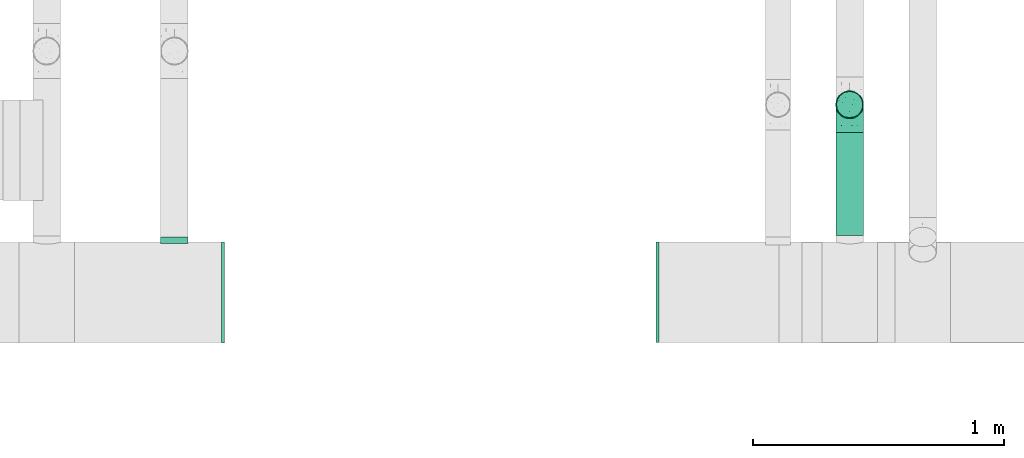
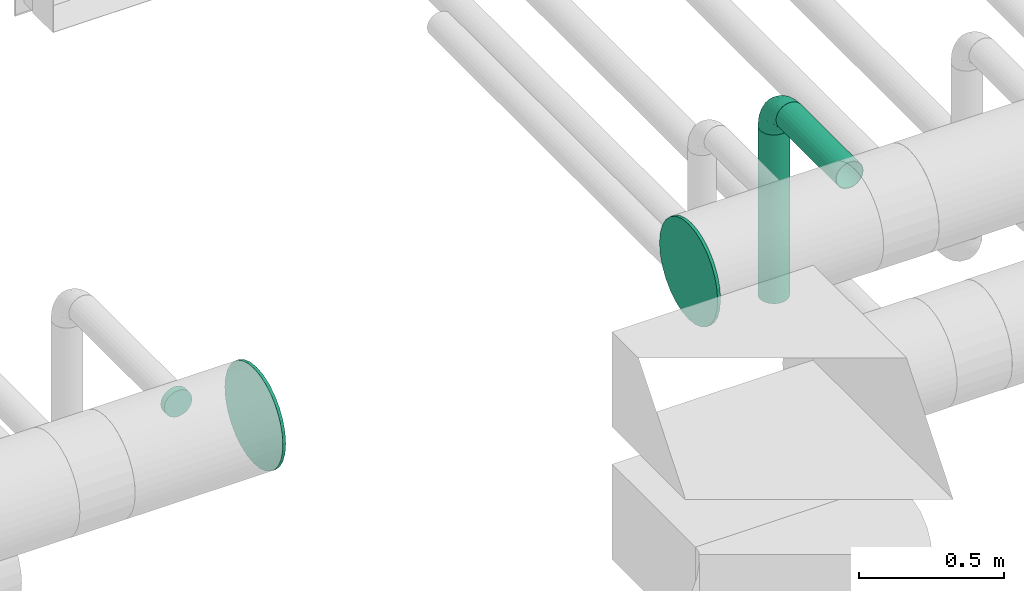
# One storey, part 72 of 91: 4 flow fittings, 2 flow segments.
"""IFC2X3 building model written with IfcOpenShell, lengths in millimetres."""

from ifc_helpers import new_model, entity, si_unit, converted_unit, derived_unit, direction, frame, origin_with_axes, origin_2d_with_axis, place, context, subcontext, project, spatial, hollow_circle, extrude, open_shell, surface_model, source, transform, mapped, material, layer, layer_set, layer_usage, type_object, element, save


model = new_model("IFC2X3")

# Units and contexts
model_context = context("Model", 3, precision=1e-05, world=origin_with_axes(), true_north=direction((0.0, 1.0)))
body_context = subcontext(model_context, "Body", "Model", "MODEL_VIEW")
ifc_project = project(units=[si_unit("AREAUNIT", "SQUARE_METRE"), si_unit("VOLUMEUNIT", "CUBIC_METRE", prefix="DECI"), si_unit("TIMEUNIT", "SECOND"), si_unit("THERMODYNAMICTEMPERATUREUNIT", "DEGREE_CELSIUS"), si_unit("PRESSUREUNIT", "PASCAL"), si_unit("MASSUNIT", "GRAM", prefix="KILO"), si_unit("LENGTHUNIT", "METRE", prefix="MILLI"), si_unit("POWERUNIT", "WATT"), si_unit("ELECTRICCURRENTUNIT", "AMPERE"), si_unit("ELECTRICVOLTAGEUNIT", "VOLT"), derived_unit("VOLUMETRICFLOWRATEUNIT", [(si_unit("VOLUMEUNIT", "CUBIC_METRE", prefix="DECI"), 1), (si_unit("TIMEUNIT", "SECOND"), -1)]), derived_unit("LINEARVELOCITYUNIT", [(si_unit("LENGTHUNIT", "METRE"), 1), (si_unit("TIMEUNIT", "SECOND"), -1)]), derived_unit("MASSDENSITYUNIT", [(si_unit("MASSUNIT", "GRAM", prefix="KILO"), 1), (si_unit("VOLUMEUNIT", "CUBIC_METRE"), -1)]), converted_unit("PLANEANGLEUNIT", "DEGREE", entity("IfcRatioMeasure", 0.01745), si_unit("PLANEANGLEUNIT", "RADIAN"), dimensions=[0, 0, 0, 0, 0, 0, 0])], contexts=[model_context])

# Site, building, storey
site_placement = place(None, origin_with_axes())
site = spatial("IfcSite", under=ifc_project, at=site_placement, CompositionType="ELEMENT")
building_placement = place(site_placement, origin_with_axes())
building = spatial("IfcBuilding", under=site, at=building_placement, Name="mc-building", CompositionType="ELEMENT")
storey_placement = place(building_placement, frame((0.0, 0.0, 8700.0), z_axis=(0.0, 0.0, 1.0), x_axis=(1.0, 0.0, 0.0)))
storey = spatial("IfcBuildingStorey", under=building, at=storey_placement, CompositionType="ELEMENT", Elevation=8700.0)

# Flow segment
ifc_material = material(Name="FZ1")
ifc_layer = layer(ifc_material, 0.0)
ifc_layer_set = layer_set([ifc_layer], Name="FZ1")
ifc_layer_usage = layer_usage(ifc_layer_set, "AXIS1", "POSITIVE", 0.0)
duct_segment_type = type_object("IfcDuctSegmentType", PredefinedType="RIGIDSEGMENT")
shared_shape_1 = source(origin_with_axes(), body_context, "Body", "SweptSolid", [
    extrude(hollow_circle(Radius=55.0, WallThickness=2.0, at=origin_2d_with_axis()), frame((0.0, 0.0, 0.0), z_axis=(1.0, 0.0, 0.0), x_axis=(0.0, 1.0, 0.0)), (0.0, 0.0, 1.0), 709.0),
])
flow_segment_1_placement = place(storey_placement, frame((29597.94843, 10827.25695, 1234.0), z_axis=(0.0, 1.0, 0.0), x_axis=(0.0, 0.0, -1.0)))
element("IfcFlowSegment", 1, at=flow_segment_1_placement, inside=storey, type_object=duct_segment_type, material=ifc_layer_usage, context=body_context, shape_type="MappedRepresentation", body=[
    mapped(shared_shape_1, transform((0.0, 0.0, 0.0), scale=1.0)),
])

# Flow fittings
duct_fitting_type_1 = type_object("IfcDuctFittingType", Name="BU", PredefinedType="BEND")
shared_shape_2 = source(origin_with_axes(), body_context, "Body", "SurfaceModel", [
    surface_model("IfcShellBasedSurfaceModel", [(-110.0, 0.0, -55.0), (-110.0, -14.23505, -53.12592), (-110.0, 14.23505, -53.12592), (-110.0, 53.12592, 14.23505), (-110.0, 27.5, -47.63139), (-110.0, 38.89087, -38.89087), (-110.0, -55.0, 0.0), (-110.0, -53.12592, 14.23505), (-110.0, -38.89087, -38.89087), (-110.0, -27.5, -47.63139), (-110.0, -53.12592, -14.23505), (-110.0, -47.63139, -27.5), (-110.0, -14.23505, 53.12592), (-110.0, 14.23505, 53.12592), (-110.0, 27.5, 47.63139), (-110.0, -47.63139, 27.5), (-110.0, -38.89087, 38.89087), (-110.0, -27.5, 47.63139), (-110.0, 0.0, 55.0), (-110.0, 55.0, 0.0), (-110.0, 53.12592, -14.23505), (-110.0, 47.63139, -27.5), (-110.0, 47.63139, 27.5), (-110.0, 38.89087, 38.89087), (-14.23505, 110.0, -53.12592), (-55.0, 110.0, 0.0), (0.0, 110.0, -55.0), (-27.5, 110.0, -47.63139), (-38.89087, 110.0, -38.89087), (-47.63139, 110.0, -27.5), (38.89087, 110.0, -38.89087), (53.12592, 110.0, 14.23505), (27.5, 110.0, -47.63139), (14.23505, 110.0, -53.12592), (47.63139, 110.0, -27.5), (53.12592, 110.0, -14.23505), (55.0, 110.0, 0.0), (-53.12592, 110.0, -14.23505), (-53.12592, 110.0, 14.23505), (-47.63139, 110.0, 27.5), (-38.89087, 110.0, 38.89087), (-27.5, 110.0, 47.63139), (0.0, 110.0, 55.0), (-14.23505, 110.0, 53.12592), (38.89087, 110.0, 38.89087), (47.63139, 110.0, 27.5), (27.5, 110.0, 47.63139), (14.23505, 110.0, 53.12592), (-64.21732, 48.68956, 43.63444), (-76.6405, 38.18013, 45.55988), (-60.44912, 32.56953, 51.94617), (-76.00813, 5.38378, 55.0), (-90.15553, 11.94394, 54.09138), (-78.5998, 26.77405, 50.81338), (-70.18771, 18.55163, 54.03432), (-75.55424, 54.2118, 32.41257), (-93.27622, 45.77614, 33.48188), (-96.12334, 22.13664, 50.81337), (-21.00813, 45.34362, 55.0), (-18.36258, 70.48427, 54.04484), (-32.04182, 59.64019, 52.24446), (-63.88653, 74.77858, 17.99134), (-74.66383, 63.08407, 19.92123), (-63.60674, 66.07878, 29.97482), (-99.597, 52.72185, 18.52927), (-93.11138, 56.59448, 10.50359), (-98.21577, 57.34403, 0.0), (-53.42855, 92.60092, 21.04759), (-88.54852, 54.8376, 21.04759), (-11.86161, 90.23965, 54.10313), (-5.38378, 76.00813, 55.0), (-57.34403, 98.21577, 0.0), (-56.64619, 93.12774, 10.22088), (-45.34362, 21.00813, 55.0), (-44.60838, 44.60838, 52.13415), (-92.68484, 35.46673, 43.63443), (-22.25266, 95.40765, 50.81337), (-35.97783, 90.61597, 43.63443), (-43.70931, 69.58671, 44.47149), (-27.23711, 77.39884, 50.81337), (-57.2828, 79.3123, 24.9774), (-58.67786, 84.31125, 16.04456), (-82.93277, 60.36161, 12.91784), (-49.88337, 54.51816, 47.224), (-74.57753, 66.83759, 9.55742), (-45.35812, 94.97281, 33.48188), (-59.18663, 88.95241, 0.0), (-51.517, 78.6292, 33.48188), (-65.14788, 80.03077, 0.0), (-56.45322, 62.06476, 39.63545), (-88.95241, 59.18663, 0.0), (-71.10913, 71.10913, 0.0), (-80.03077, 65.14788, 0.0), (-94.9309, 45.36788, -33.48188), (-93.11358, 56.60141, -10.46614), (-99.64997, 52.79499, -18.30015), (-90.20425, 36.08686, -43.63443), (-79.99933, 46.56772, -37.92748), (-76.00813, 5.38378, -55.0), (-72.75364, 19.68651, -53.60527), (-45.34362, 21.00813, -55.0), (-21.91957, 65.12078, -53.85897), (-5.38378, 76.00813, -55.0), (-21.00813, 45.34362, -55.0), (-35.41876, 92.89265, -43.63443), (-91.10309, 11.02766, -54.21832), (-45.77614, 93.27622, -33.48188), (-90.50474, 23.21022, -50.81337), (-70.92854, 33.31794, -49.51754), (-78.52933, 63.35627, -11.73997), (-24.91508, 84.05606, -50.81337), (-88.78941, 54.74452, -21.04759), (-69.59921, 57.34866, -33.48187), (-73.36422, 62.46673, -22.94182), (-63.49062, 67.59111, -28.46929), (-56.59448, 93.11138, -10.50359), (-54.8376, 88.54852, -21.04759), (-54.10679, 75.85581, -32.31867), (-57.75956, 31.09612, -52.80882), (-52.72185, 99.597, -18.52927), (-12.62913, 89.46304, -53.99097), (-34.46825, 66.46123, -50.04329), (-43.9837, 43.9837, -52.42279), (-65.78527, 72.58348, -17.68796), (-70.34468, 43.65295, -44.21951), (-57.47001, 51.99467, -44.91465), (-60.72547, 82.29174, -12.88567), (-42.34915, 74.24548, -43.63444), (-57.25194, 63.5016, -38.08211), (-80.95344, 53.56991, -29.32027), (-52.32891, 4.55257, -54.0482), (32.52942, 47.13398, -30.48571), (14.88266, 20.92917, -33.7947), (14.95561, 36.05775, -42.26543), (30.24048, 70.09027, -41.7461), (19.3559, 65.35825, -48.00507), (-70.35075, -46.44478, -19.5952), (-47.13398, -32.52942, -30.48571), (-28.49299, -30.5778, -16.4009), (-4.55257, 52.32891, -54.0482), (-22.4954, 22.4954, -53.25347), (-75.47368, -11.22546, -52.60718), (-81.32209, -51.5606, -9.98467), (-80.81763, -41.84862, -32.14655), (-70.09027, -30.24048, -41.7461), (-36.05774, -14.95561, -42.26543), (-9.15831, -10.852, -27.8997), (-65.35825, -19.3559, -48.00507), (11.22546, 75.47368, -52.60718), (3.94376, 43.9333, -50.53315), (-13.39742, 13.39743, -48.13058), (-43.9333, -3.94376, -50.53315), (49.37776, 67.29486, 0.0), (41.8609, 47.82256, -9.92641), (50.20582, 74.51695, -9.9731), (18.93131, 11.7156, -17.56239), (-27.5, -32.89419, 0.0), (-1.23348, -12.25375, -12.18106), (41.84862, 80.81763, -32.14655), (35.70604, 41.31408, -20.38235), (46.44478, 70.35075, -19.5952), (32.89419, 27.5, 0.0), (6.67262, -6.67262, 0.0), (-67.29486, -49.37776, 0.0), (-50.36265, -42.95545, -9.51562), (-5.47251, 5.47251, -39.92906), (-70.35075, -46.44478, 19.5952), (-74.51695, -50.20582, 9.9731), (-41.31407, -35.70604, 20.38235), (-47.13398, -32.52942, 30.48571), (-80.81763, -41.84862, 32.14655), (-4.55257, 52.32891, 54.0482), (11.22546, 75.47368, 52.60718), (-43.9333, -3.94376, 50.53315), (-65.35825, -19.3559, 48.00507), (-36.05774, -14.95561, 42.26543), (-70.09027, -30.24048, 41.7461), (-11.7156, -18.93131, 17.56239), (30.5778, 28.49299, 16.4009), (12.25375, 1.23348, 12.18106), (51.5606, 81.32209, 9.98467), (42.95545, 50.36265, 9.51562), (-75.47368, -11.22546, 52.60718), (-52.32891, 4.55257, 54.0482), (3.94376, 43.9333, 50.53315), (-22.4954, 22.4954, 53.25347), (-13.39742, 13.39743, 48.13058), (10.852, 9.15831, 27.8997), (-20.92916, -14.88266, 33.79469), (-47.82256, -41.8609, 9.92641), (32.52942, 47.13398, 30.48571), (46.44478, 70.35075, 19.5952), (41.84862, 80.81763, 32.14655), (30.24048, 70.09027, 41.7461), (19.3559, 65.35825, 48.00507), (14.95561, 36.05775, 42.26543), (-5.47251, 5.47251, 39.92906)], [open_shell([[[0, 1, 2]], [[2, 3, 4]], [[4, 3, 5]], [[2, 6, 7]], [[8, 6, 9]], [[1, 9, 6]], [[10, 6, 11]], [[8, 11, 6]], [[6, 2, 1]], [[12, 13, 14]], [[15, 2, 7]], [[16, 17, 2]], [[2, 17, 12]], [[12, 18, 13]], [[19, 20, 3]], [[5, 3, 21]], [[20, 21, 3]], [[22, 3, 2]], [[23, 22, 2]], [[12, 14, 2]], [[2, 14, 23]], [[15, 16, 2]], [[24, 25, 26]], [[27, 25, 24]], [[25, 28, 29]], [[28, 25, 27]], [[30, 26, 31]], [[26, 30, 32]], [[32, 33, 26]], [[34, 31, 35]], [[31, 34, 30]], [[35, 31, 36]], [[29, 37, 25]], [[38, 39, 26]], [[39, 40, 26]], [[41, 42, 40]], [[42, 26, 40]], [[42, 41, 43]], [[26, 44, 45]], [[31, 26, 45]], [[26, 46, 44]], [[47, 46, 26]], [[42, 47, 26]], [[25, 38, 26]], [[48, 49, 50]], [[18, 51, 52]], [[53, 54, 50]], [[55, 56, 49]], [[56, 22, 23]], [[13, 57, 14]], [[58, 59, 60]], [[61, 62, 63]], [[3, 64, 65]], [[53, 52, 54]], [[3, 65, 66]], [[67, 39, 38]], [[56, 68, 64]], [[65, 64, 68]], [[69, 59, 70]], [[38, 71, 72]], [[73, 58, 74]], [[75, 49, 56]], [[76, 69, 43]], [[53, 57, 52]], [[77, 78, 79]], [[41, 76, 43]], [[43, 69, 42]], [[55, 68, 56]], [[23, 14, 75]], [[76, 77, 79]], [[80, 67, 81]], [[62, 82, 68]], [[60, 78, 83]], [[62, 84, 82]], [[85, 77, 40]], [[81, 67, 72]], [[86, 72, 71]], [[87, 85, 67]], [[61, 81, 88]], [[77, 41, 40]], [[78, 77, 87]], [[23, 75, 56]], [[83, 89, 48]], [[85, 40, 39]], [[62, 68, 55]], [[89, 87, 63]], [[83, 48, 50]], [[57, 75, 14]], [[49, 75, 53]], [[67, 85, 39]], [[87, 77, 85]], [[63, 62, 55]], [[89, 55, 48]], [[80, 63, 87]], [[66, 65, 90]], [[66, 19, 3]], [[84, 91, 92]], [[92, 90, 82]], [[65, 82, 90]], [[61, 84, 62]], [[92, 82, 84]], [[68, 82, 65]], [[3, 22, 64]], [[56, 64, 22]], [[38, 25, 71]], [[81, 72, 86]], [[38, 72, 67]], [[91, 61, 88]], [[80, 81, 61]], [[63, 80, 61]], [[67, 80, 87]], [[77, 76, 41]], [[79, 59, 69]], [[79, 69, 76]], [[42, 69, 70]], [[60, 59, 79]], [[58, 70, 59]], [[78, 60, 79]], [[58, 60, 74]], [[52, 57, 13]], [[75, 57, 53]], [[18, 52, 13]], [[52, 51, 54]], [[51, 73, 54]], [[50, 73, 74]], [[73, 50, 54]], [[50, 74, 83]], [[60, 83, 74]], [[89, 83, 78]], [[87, 89, 78]], [[55, 89, 63]], [[50, 49, 53]], [[55, 49, 48]], [[81, 86, 88]], [[91, 84, 61]], [[5, 21, 93]], [[90, 94, 66]], [[20, 94, 95]], [[96, 93, 97]], [[98, 99, 100]], [[96, 4, 5]], [[101, 102, 103]], [[28, 27, 104]], [[2, 105, 0]], [[104, 106, 28]], [[99, 105, 107]], [[108, 107, 96]], [[90, 109, 94]], [[107, 2, 4]], [[20, 66, 94]], [[27, 24, 110]], [[109, 111, 94]], [[112, 113, 114]], [[37, 115, 71]], [[116, 106, 117]], [[99, 118, 100]], [[116, 115, 119]], [[37, 119, 115]], [[24, 120, 110]], [[121, 110, 101]], [[119, 106, 116]], [[101, 110, 120]], [[122, 103, 100]], [[117, 123, 116]], [[124, 125, 108]], [[115, 116, 126]], [[106, 29, 28]], [[26, 102, 120]], [[127, 104, 110]], [[97, 124, 96]], [[125, 122, 118]], [[128, 127, 125]], [[96, 5, 93]], [[115, 126, 86]], [[117, 106, 127]], [[111, 113, 129]], [[95, 93, 21]], [[97, 129, 112]], [[110, 104, 27]], [[106, 104, 127]], [[96, 107, 4]], [[99, 107, 108]], [[99, 108, 118]], [[105, 99, 98]], [[112, 114, 128]], [[121, 125, 127]], [[20, 19, 66]], [[109, 90, 92]], [[94, 111, 95]], [[91, 123, 109]], [[129, 113, 112]], [[93, 95, 111]], [[21, 20, 95]], [[71, 115, 86]], [[71, 25, 37]], [[123, 91, 88]], [[126, 116, 123]], [[123, 88, 126]], [[86, 126, 88]], [[37, 29, 119]], [[106, 119, 29]], [[129, 93, 111]], [[124, 112, 125]], [[0, 105, 98]], [[107, 105, 2]], [[125, 118, 108]], [[100, 118, 122]], [[93, 129, 97]], [[113, 111, 109]], [[109, 123, 113]], [[114, 123, 117]], [[123, 114, 113]], [[128, 114, 117]], [[127, 128, 117]], [[112, 128, 125]], [[103, 122, 101]], [[110, 121, 127]], [[101, 122, 121]], [[125, 121, 122]], [[26, 120, 24]], [[101, 120, 102]], [[96, 124, 108]], [[92, 91, 109]], [[112, 124, 97]], [[100, 130, 98]], [[131, 132, 133]], [[32, 134, 135]], [[136, 137, 138]], [[139, 140, 103]], [[98, 141, 0]], [[142, 10, 136]], [[143, 144, 137]], [[6, 10, 142]], [[137, 145, 146]], [[144, 147, 145]], [[143, 136, 11]], [[11, 136, 10]], [[8, 143, 11]], [[148, 149, 139]], [[8, 9, 144]], [[9, 1, 147]], [[130, 141, 98]], [[103, 140, 100]], [[148, 135, 149]], [[150, 151, 140]], [[152, 153, 154]], [[130, 140, 151]], [[148, 26, 33]], [[147, 1, 141]], [[155, 146, 132]], [[156, 138, 157]], [[134, 30, 158]], [[150, 140, 149]], [[158, 30, 34]], [[30, 134, 32]], [[153, 159, 160]], [[131, 160, 159]], [[144, 145, 137]], [[36, 152, 154]], [[146, 138, 137]], [[155, 161, 162]], [[158, 160, 131]], [[133, 149, 135]], [[156, 163, 164]], [[163, 142, 164]], [[139, 103, 102]], [[153, 152, 161]], [[34, 35, 160]], [[162, 157, 155]], [[132, 165, 133]], [[157, 146, 155]], [[140, 130, 100]], [[141, 130, 151]], [[141, 151, 147]], [[141, 1, 0]], [[102, 26, 148]], [[140, 139, 149]], [[102, 148, 139]], [[135, 33, 32]], [[151, 150, 145]], [[9, 147, 144]], [[151, 145, 147]], [[145, 165, 146]], [[135, 148, 33]], [[133, 135, 134]], [[131, 133, 134]], [[133, 165, 150]], [[133, 150, 149]], [[145, 150, 165]], [[132, 131, 159]], [[146, 165, 132]], [[160, 158, 34]], [[134, 158, 131]], [[144, 143, 8]], [[136, 143, 137]], [[155, 153, 161]], [[154, 153, 160]], [[153, 155, 159]], [[132, 159, 155]], [[160, 35, 154]], [[36, 154, 35]], [[164, 136, 138]], [[6, 142, 163]], [[136, 164, 142]], [[156, 164, 138]], [[156, 157, 162]], [[146, 157, 138]], [[15, 7, 166]], [[6, 163, 167]], [[168, 169, 166]], [[166, 169, 170]], [[171, 172, 70]], [[173, 174, 175]], [[17, 176, 174]], [[177, 156, 162]], [[176, 16, 170]], [[170, 16, 15]], [[161, 178, 179]], [[152, 180, 181]], [[182, 173, 183]], [[18, 12, 182]], [[184, 185, 186]], [[183, 185, 73]], [[183, 73, 51]], [[177, 187, 188]], [[189, 168, 166]], [[187, 178, 190]], [[16, 176, 17]], [[161, 152, 181]], [[45, 191, 31]], [[45, 44, 192]], [[192, 191, 45]], [[180, 36, 31]], [[193, 194, 195]], [[46, 47, 194]], [[193, 195, 190]], [[193, 44, 46]], [[172, 42, 70]], [[185, 58, 73]], [[189, 163, 156]], [[163, 189, 167]], [[70, 58, 171]], [[184, 171, 185]], [[169, 188, 175]], [[180, 31, 191]], [[192, 193, 190]], [[191, 190, 178]], [[182, 174, 173]], [[194, 47, 172]], [[190, 195, 187]], [[186, 185, 173]], [[162, 179, 177]], [[188, 196, 175]], [[179, 187, 177]], [[185, 171, 58]], [[172, 171, 184]], [[172, 184, 194]], [[172, 47, 42]], [[51, 18, 182]], [[185, 183, 173]], [[51, 182, 183]], [[174, 12, 17]], [[184, 186, 195]], [[46, 194, 193]], [[184, 195, 194]], [[195, 196, 187]], [[174, 182, 12]], [[175, 174, 176]], [[169, 175, 176]], [[175, 196, 186]], [[175, 186, 173]], [[195, 186, 196]], [[188, 169, 168]], [[187, 196, 188]], [[166, 170, 15]], [[176, 170, 169]], [[193, 192, 44]], [[191, 192, 190]], [[177, 189, 156]], [[167, 189, 166]], [[189, 177, 168]], [[188, 168, 177]], [[166, 7, 167]], [[6, 167, 7]], [[181, 191, 178]], [[36, 180, 152]], [[191, 181, 180]], [[161, 181, 178]], [[161, 179, 162]], [[187, 179, 178]]])]),
])
flow_fitting_1_placement = place(storey_placement, frame((29597.94843, 10827.25695, 1344.0), z_axis=(1.0, 0.0, 0.0), x_axis=(0.0, 0.0, 1.0)))
element("IfcFlowFitting", 2, at=flow_fitting_1_placement, inside=storey, type_object=duct_fitting_type_1, Name="BU", context=body_context, shape_type="MappedRepresentation", body=[
    mapped(shared_shape_2, transform((0.0, 0.0, 0.0), scale=1.0)),
])
duct_fitting_type_2 = type_object("IfcDuctFittingType", Name="CC", PredefinedType="CONNECTOR")
shared_shape_3 = source(origin_with_axes(), body_context, "Body", "SurfaceModel", [
    surface_model("IfcShellBasedSurfaceModel", [(-6.096, -38.89087, -38.89087), (-6.096, -55.0, 0.0), (-6.096, -27.5, -47.63139), (-6.096, 47.63139, -27.5), (-6.096, 53.12592, 14.23505), (-6.096, 53.12592, -14.23505), (-6.096, 55.0, 0.0), (-6.096, -53.12592, -14.23505), (-6.096, -47.63139, -27.5), (20.0, 38.89087, -38.89087), (20.0, 55.0, 0.0), (20.0, 27.5, -47.63139), (20.0, 53.12592, -14.23505), (20.0, 47.63139, -27.5), (20.0, -47.63139, -27.5), (20.0, -53.12592, 14.23505), (20.0, -53.12592, -14.23505), (20.0, -55.0, 0.0), (-6.096, 0.0, -55.0), (-6.096, -14.23505, -53.12592), (-6.096, 14.23505, -53.12592), (-6.096, 27.5, -47.63139), (-6.096, 38.89087, -38.89087), (-6.096, -53.12592, 14.23505), (-6.096, 47.63139, 27.5), (-6.096, 38.89087, 38.89087), (-6.096, -14.23505, 53.12592), (-6.096, 27.5, 47.63139), (-6.096, 14.23505, 53.12592), (-6.096, -47.63139, 27.5), (-6.096, -38.89087, 38.89087), (-6.096, -27.5, 47.63139), (-6.096, 0.0, 55.0), (0.0, 0.0, 55.0), (0.0, 14.23505, 53.12592), (0.0, 27.5, 47.63139), (0.0, 38.89087, 38.89087), (0.0, 47.63139, 27.5), (0.0, 53.12592, 14.23505), (0.0, 55.0, 0.0), (0.0, 53.12592, -14.23505), (0.0, 47.63139, -27.5), (0.0, 38.89087, -38.89087), (0.0, 27.5, -47.63139), (0.0, 14.23505, -53.12592), (0.0, 0.0, -55.0), (0.0, -14.23505, -53.12592), (0.0, -27.5, -47.63139), (0.0, -38.89087, -38.89087), (0.0, -47.63139, -27.5), (0.0, -53.12592, -14.23505), (0.0, -55.0, 0.0), (0.0, -53.12592, 14.23505), (0.0, -47.63139, 27.5), (0.0, -38.89087, 38.89087), (0.0, -27.5, 47.63139), (0.0, -14.23505, 53.12592), (20.0, 0.0, -55.0), (20.0, 14.23505, -53.12592), (20.0, -38.89087, -38.89087), (20.0, -27.5, -47.63139), (20.0, -14.23505, -53.12592), (20.0, 53.12592, 14.23505), (20.0, 47.63139, 27.5), (20.0, 38.89087, 38.89087), (20.0, 0.0, 55.0), (20.0, 27.5, 47.63139), (20.0, 14.23505, 53.12592), (20.0, -38.89087, 38.89087), (20.0, -47.63139, 27.5), (20.0, -14.23505, 53.12592), (20.0, -27.5, 47.63139)], [open_shell([[[0, 1, 2]], [[3, 4, 5]], [[6, 5, 4]], [[7, 1, 8]], [[9, 10, 11]], [[12, 10, 13]], [[14, 15, 16]], [[17, 16, 15]], [[18, 19, 20]], [[20, 4, 21]], [[3, 22, 4]], [[21, 4, 22]], [[20, 1, 23]], [[19, 2, 1]], [[0, 8, 1]], [[1, 20, 19]], [[20, 24, 4]], [[25, 24, 20]], [[26, 27, 20]], [[27, 25, 20]], [[26, 28, 27]], [[20, 29, 30]], [[29, 20, 23]], [[30, 31, 20]], [[20, 31, 26]], [[26, 32, 28]], [[32, 33, 34]], [[28, 34, 35]], [[32, 34, 28]], [[27, 36, 25]], [[27, 28, 35]], [[36, 27, 35]], [[24, 37, 38]], [[4, 38, 39]], [[25, 37, 24]], [[4, 24, 38]], [[6, 4, 39]], [[37, 25, 36]], [[6, 39, 40]], [[5, 40, 41]], [[6, 40, 5]], [[3, 42, 22]], [[3, 5, 41]], [[42, 3, 41]], [[21, 43, 44]], [[20, 44, 45]], [[22, 43, 21]], [[20, 21, 44]], [[18, 20, 45]], [[43, 22, 42]], [[18, 45, 46]], [[19, 46, 47]], [[18, 46, 19]], [[2, 48, 0]], [[2, 19, 47]], [[48, 2, 47]], [[8, 49, 50]], [[7, 50, 51]], [[0, 49, 8]], [[7, 8, 50]], [[1, 7, 51]], [[49, 0, 48]], [[1, 51, 52]], [[23, 52, 53]], [[1, 52, 23]], [[29, 54, 30]], [[29, 23, 53]], [[54, 29, 53]], [[31, 55, 56]], [[26, 56, 33]], [[30, 55, 31]], [[26, 31, 56]], [[32, 26, 33]], [[55, 30, 54]], [[10, 57, 58]], [[11, 10, 58]], [[10, 9, 13]], [[59, 57, 15]], [[57, 59, 60]], [[60, 61, 57]], [[59, 15, 14]], [[62, 63, 57]], [[57, 63, 64]], [[65, 64, 66]], [[65, 57, 64]], [[67, 65, 66]], [[68, 69, 57]], [[15, 57, 69]], [[70, 71, 57]], [[71, 68, 57]], [[70, 57, 65]], [[10, 62, 57]], [[33, 65, 67]], [[34, 67, 66]], [[33, 67, 34]], [[35, 64, 36]], [[35, 34, 66]], [[64, 35, 66]], [[37, 63, 62]], [[38, 62, 10]], [[36, 63, 37]], [[38, 37, 62]], [[39, 38, 10]], [[63, 36, 64]], [[39, 10, 12]], [[40, 12, 13]], [[39, 12, 40]], [[41, 9, 42]], [[41, 40, 13]], [[9, 41, 13]], [[43, 11, 58]], [[44, 58, 57]], [[42, 11, 43]], [[44, 43, 58]], [[45, 44, 57]], [[11, 42, 9]], [[45, 57, 61]], [[46, 61, 60]], [[45, 61, 46]], [[47, 59, 48]], [[47, 46, 60]], [[59, 47, 60]], [[49, 14, 16]], [[50, 16, 17]], [[48, 14, 49]], [[50, 49, 16]], [[51, 50, 17]], [[14, 48, 59]], [[51, 17, 15]], [[52, 15, 69]], [[51, 15, 52]], [[53, 68, 54]], [[53, 52, 69]], [[68, 53, 69]], [[55, 71, 70]], [[56, 70, 65]], [[54, 71, 55]], [[56, 55, 70]], [[33, 56, 65]], [[71, 54, 68]], [[65, 57, 66]], [[57, 64, 66]], [[65, 66, 67]], [[69, 15, 57]]])]),
])
flow_fitting_2_placement = place(storey_placement, frame((26911.82755, 10280.05037, 1344.0), z_axis=(0.0, 0.0, -1.0), x_axis=(0.0, 1.0, 0.0)))
element("IfcFlowFitting", 3, at=flow_fitting_2_placement, inside=storey, type_object=duct_fitting_type_2, Name="CC", context=body_context, shape_type="MappedRepresentation", body=[
    mapped(shared_shape_3, transform((0.0, 0.0, 0.0), scale=1.0)),
])
duct_fitting_type_3 = type_object("IfcDuctFittingType", Name="ESU", PredefinedType="OBSTRUCTION")
shared_shape_4 = source(origin_with_axes(), body_context, "Body", "SurfaceModel", [
    surface_model("IfcShellBasedSurfaceModel", [(0.0, 86.77674, -180.19378), (0.0, 44.50419, -194.98559), (0.0, 0.0, -200.0), (0.0, 124.69796, -156.36629), (0.0, 180.19378, -86.77674), (0.0, 194.98559, -44.50419), (0.0, 156.36629, -124.69796), (0.0, 0.0, 200.0), (0.0, -194.98559, -44.50419), (0.0, -86.77674, -180.19378), (0.0, -124.69796, -156.36629), (0.0, -44.50419, -194.98559), (0.0, -180.19378, -86.77674), (0.0, -156.36629, -124.69796), (0.0, -200.0, 0.0), (0.0, -194.98559, 44.50419), (0.0, 200.0, 0.0), (0.0, 180.19378, 86.77674), (0.0, 194.98559, 44.50419), (0.0, 156.36629, 124.69796), (0.0, 86.77674, 180.19378), (0.0, 124.69796, 156.36629), (0.0, 44.50419, 194.98559), (0.0, -180.19378, 86.77674), (0.0, -156.36629, 124.69796), (0.0, -86.77674, 180.19378), (0.0, -44.50419, 194.98559), (0.0, -124.69796, 156.36629), (12.0, 44.50419, -194.98559), (12.0, -44.50419, -194.98559), (12.0, 0.0, -200.0), (12.0, 86.77674, -180.19378), (12.0, 156.36629, -124.69796), (12.0, 180.19378, -86.77674), (12.0, 124.69796, -156.36629), (12.0, 194.98559, -44.50419), (12.0, -124.69796, -156.36629), (12.0, -86.77674, -180.19378), (12.0, -194.98559, -44.50419), (12.0, -156.36629, -124.69796), (12.0, -180.19378, -86.77674), (12.0, -200.0, 0.0), (12.0, 44.50419, 194.98559), (12.0, 86.77674, 180.19378), (12.0, 194.98559, 44.50419), (12.0, 180.19378, 86.77674), (12.0, 156.36629, 124.69796), (12.0, 124.69796, 156.36629), (12.0, -44.50419, 194.98559), (12.0, -180.19378, 86.77674), (12.0, -194.98559, 44.50419), (12.0, -156.36629, 124.69796), (12.0, -124.69796, 156.36629), (12.0, -86.77674, 180.19378), (12.0, 0.0, 200.0), (12.0, 200.0, 0.0)], [open_shell([[[0, 1, 2]], [[3, 0, 2]], [[4, 2, 5]], [[6, 2, 4]], [[6, 3, 2]], [[7, 2, 8]], [[9, 10, 11]], [[8, 11, 10]], [[12, 10, 13]], [[8, 10, 12]], [[11, 8, 2]], [[14, 15, 8]], [[5, 2, 16]], [[17, 18, 16]], [[19, 17, 16]], [[16, 20, 21]], [[22, 20, 2]], [[21, 19, 16]], [[2, 7, 22]], [[23, 24, 8]], [[8, 15, 23]], [[25, 26, 7]], [[25, 8, 27]], [[8, 24, 27]], [[8, 25, 7]], [[2, 20, 16]], [[28, 29, 30]], [[31, 29, 28]], [[32, 33, 29]], [[32, 29, 34]], [[29, 31, 34]], [[29, 33, 35]], [[29, 36, 37]], [[36, 29, 38]], [[39, 36, 40]], [[38, 40, 36]], [[41, 38, 29]], [[41, 29, 42]], [[29, 35, 43]], [[44, 45, 35]], [[35, 45, 46]], [[47, 43, 35]], [[42, 29, 43]], [[46, 47, 35]], [[48, 41, 42]], [[41, 49, 50]], [[51, 49, 41]], [[41, 52, 51]], [[41, 53, 52]], [[53, 41, 48]], [[42, 54, 48]], [[55, 44, 35]], [[7, 54, 42]], [[42, 43, 22]], [[47, 20, 43]], [[7, 42, 22]], [[20, 22, 43]], [[21, 20, 47]], [[47, 46, 21]], [[19, 46, 45]], [[45, 44, 17]], [[55, 18, 44]], [[19, 45, 17]], [[18, 17, 44]], [[16, 18, 55]], [[46, 19, 21]], [[16, 55, 35]], [[35, 33, 5]], [[32, 4, 33]], [[16, 35, 5]], [[4, 5, 33]], [[6, 4, 32]], [[32, 34, 6]], [[34, 31, 3]], [[31, 28, 1]], [[2, 28, 30]], [[3, 31, 0]], [[0, 31, 1]], [[28, 2, 1]], [[34, 3, 6]], [[2, 30, 29]], [[29, 37, 11]], [[36, 9, 37]], [[2, 29, 11]], [[9, 11, 37]], [[10, 9, 36]], [[36, 39, 10]], [[39, 40, 13]], [[38, 41, 8]], [[40, 38, 8]], [[13, 40, 12]], [[14, 8, 41]], [[40, 8, 12]], [[39, 13, 10]], [[14, 41, 50]], [[50, 49, 15]], [[51, 23, 49]], [[14, 50, 15]], [[23, 15, 49]], [[24, 23, 51]], [[51, 52, 24]], [[27, 52, 53]], [[25, 53, 48]], [[26, 48, 54]], [[27, 53, 25]], [[26, 25, 48]], [[7, 26, 54]], [[52, 27, 24]]])]),
])
for number, where, z_axis, x_axis in (
    (4, (27099.96538, 10080.05037, 1344.0), (0.0, 0.0, 1.0), (1.0, 0.0, 0.0)),
    (5, (28840.24579, 10080.96985, 1344.0), (0.0, 0.0, 1.0), (-1.0, 0.0, 0.0)),
):
    element("IfcFlowFitting", number, at=place(storey_placement, frame(where, z_axis=z_axis, x_axis=x_axis)), inside=storey, type_object=duct_fitting_type_3, context=body_context, shape_type="MappedRepresentation", body=[
        mapped(shared_shape_4, transform((0.0, 0.0, 0.0), scale=1.0)),
    ])

# Flow segment
shared_shape_5 = source(origin_with_axes(), body_context, "Body", "SweptSolid", [
    extrude(hollow_circle(Radius=55.0, WallThickness=2.0, at=origin_2d_with_axis()), frame((0.0, 0.0, 0.0), z_axis=(1.0, 0.0, 0.0), x_axis=(0.0, 1.0, 0.0)), (0.0, 0.0, 1.0), 411.3),
])
flow_segment_2_placement = place(storey_placement, frame((29597.94843, 10305.96985, 1344.0), z_axis=(0.0, 0.0, 1.0), x_axis=(0.0, 1.0, 0.0)))
element("IfcFlowSegment", 6, at=flow_segment_2_placement, inside=storey, type_object=duct_segment_type, material=ifc_layer_usage, context=body_context, shape_type="MappedRepresentation", body=[
    mapped(shared_shape_5, transform((0.0, 0.0, 0.0), scale=1.0)),
])

save(model, "model.ifc")
